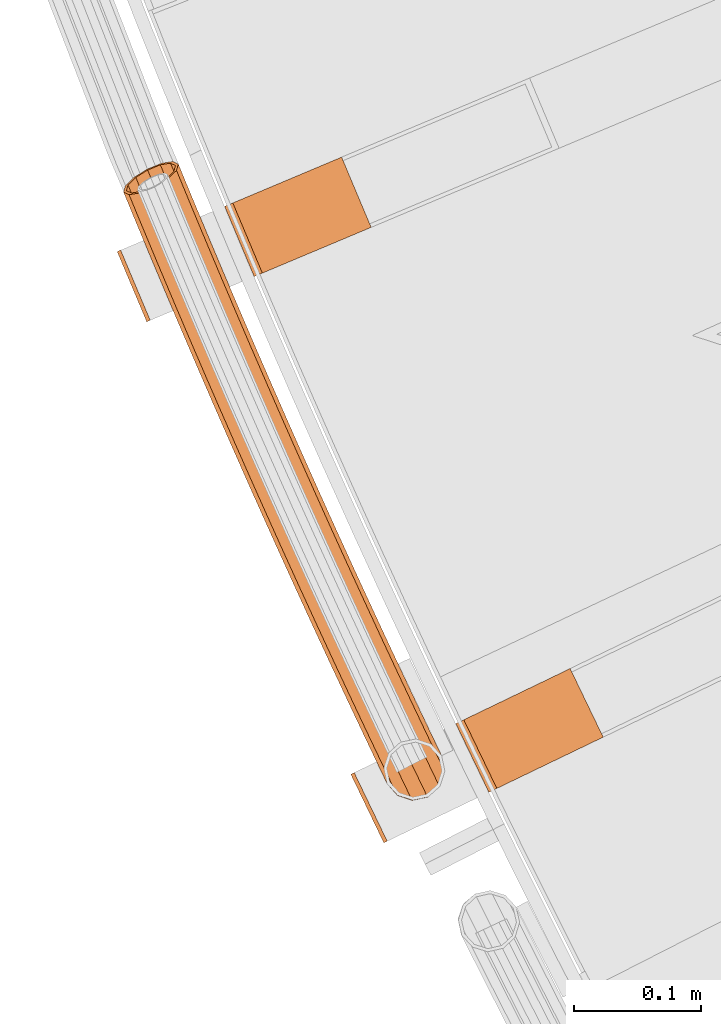
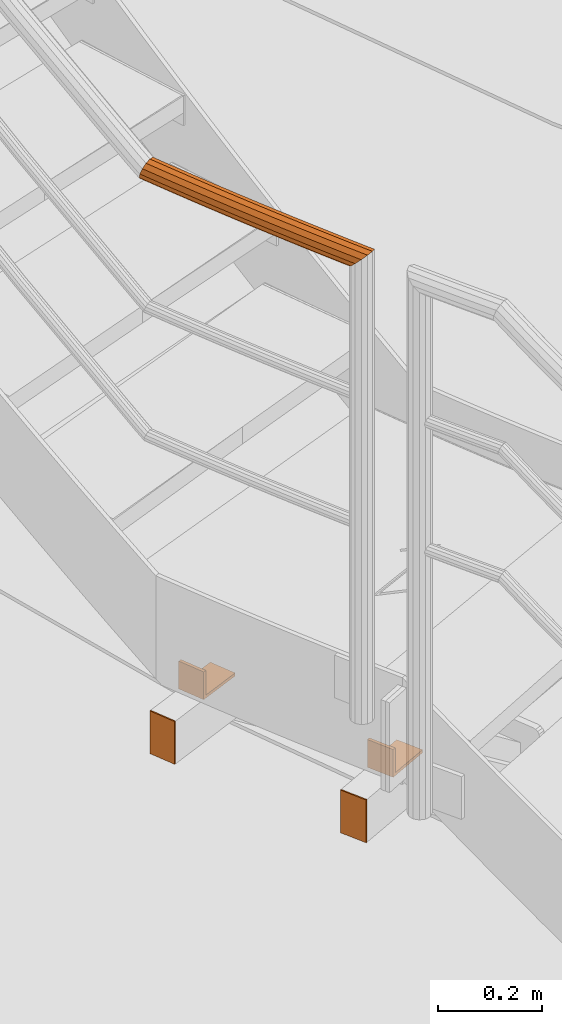
# One storey, part 47 of 126: 5 proxies.
"""IFC2X3 building model written with IfcOpenShell, lengths in millimetres."""

from ifc_helpers import new_model, si_unit, origin, origin_with_axes, place, context, project, spatial, faceted_brep, material, element, save


model = new_model("IFC2X3")

# Units and contexts
context_of_model_1 = context(None, 3, precision=0.1, world=origin())
context_of_model_2 = context(None, 3, precision=0.1, world=origin())
ifc_project = project(units=[si_unit("LENGTHUNIT", "METRE", prefix="MILLI"), si_unit("AREAUNIT", "SQUARE_METRE", prefix="CENTI"), si_unit("VOLUMEUNIT", "CUBIC_METRE", prefix="CENTI"), si_unit("MASSUNIT", "GRAM", prefix="KILO")], contexts=[context_of_model_1, context_of_model_2])

# Site, building, storey
site_placement = place(None, origin_with_axes())
site = spatial("IfcSite", under=ifc_project, at=site_placement, CompositionType="ELEMENT")
building_placement = place(site_placement, origin_with_axes())
building = spatial("IfcBuilding", under=site, at=building_placement, CompositionType="ELEMENT")
storey_placement = place(building_placement, origin_with_axes())
storey = spatial("IfcBuildingStorey", under=building, at=storey_placement, CompositionType="ELEMENT")

# Proxies
ifc_material = material(Name="S235JRG2")
proxy_1_placement = place(storey_placement, origin_with_axes())
element("IfcBuildingElementProxy", 1, at=proxy_1_placement, inside=storey, material=ifc_material, context=context_of_model_2, shape_type="Brep", body=[
    faceted_brep([(-35.5375, 4164.3292, 2521.2501), (-32.8349, 4165.6314, 2521.2501), (-6.7918, 4111.5781, 2521.2501), (-9.4944, 4110.276, 2521.2501), (-35.5375, 4164.3292, 2621.25), (-9.4944, 4110.276, 2621.25), (-6.7918, 4111.5781, 2621.25), (-32.8349, 4165.6314, 2621.25)], [[[0, 1, 2, 3]], [[4, 5, 6, 7]], [[0, 4, 7, 1]], [[1, 7, 6, 2]], [[2, 6, 5, 3]], [[3, 5, 4, 0]]]),
])
proxy_2_placement = place(storey_placement, origin_with_axes())
element("IfcBuildingElementProxy", 2, at=proxy_2_placement, inside=storey, material=ifc_material, context=context_of_model_2, shape_type="Brep", body=[
    faceted_brep([(73.2177, 4150.1271, 2686.25), (47.1746, 4204.1803, 2686.25), (47.1746, 4204.1803, 2621.25), (73.2177, 4150.1271, 2621.25), (79.5239, 4153.1655, 2686.25), (53.4808, 4207.2187, 2686.25), (79.5239, 4153.1655, 2628.25), (53.4808, 4207.2187, 2628.25), (163.3065, 4193.5323, 2628.25), (137.2634, 4247.5856, 2628.25), (163.3065, 4193.5323, 2621.25), (137.2634, 4247.5856, 2621.25)], [[[0, 1, 2, 3]], [[0, 4, 5, 1]], [[4, 6, 7, 5]], [[6, 8, 9, 7]], [[8, 10, 11, 9]], [[3, 2, 11, 10]], [[3, 10, 8, 6, 4, 0]], [[1, 5, 7, 9, 11, 2]]]),
])
proxy_3_placement = place(storey_placement, origin_with_axes())
element("IfcBuildingElementProxy", 3, at=proxy_3_placement, inside=storey, material=ifc_material, context=context_of_model_2, shape_type="Brep", body=[
    faceted_brep([(-219.5513, 4576.0422, 2521.2501), (-216.7862, 4577.206, 2521.2501), (-193.5112, 4521.9043, 2521.2501), (-196.2762, 4520.7406, 2521.2501), (-219.5513, 4576.0422, 2621.25), (-196.2762, 4520.7406, 2621.25), (-193.5112, 4521.9043, 2621.25), (-216.7862, 4577.206, 2621.25)], [[[0, 1, 2, 3]], [[4, 5, 6, 7]], [[0, 4, 7, 1]], [[1, 7, 6, 2]], [[2, 6, 5, 3]], [[3, 5, 4, 0]]]),
])
proxy_4_placement = place(storey_placement, origin_with_axes())
element("IfcBuildingElementProxy", 4, at=proxy_4_placement, inside=storey, material=ifc_material, context=context_of_model_2, shape_type="Brep", body=[
    faceted_brep([(-111.6539, 4556.356, 2686.25), (-134.9289, 4611.6576, 2686.25), (-134.9289, 4611.6576, 2621.25), (-111.6539, 4556.356, 2621.25), (-105.202, 4559.0714, 2686.25), (-128.4771, 4614.373, 2686.25), (-105.202, 4559.0714, 2628.25), (-128.4771, 4614.373, 2628.25), (-19.4845, 4595.1478, 2628.25), (-42.7595, 4650.4494, 2628.25), (-19.4845, 4595.1478, 2621.25), (-42.7595, 4650.4494, 2621.25)], [[[0, 1, 2, 3]], [[0, 4, 5, 1]], [[4, 6, 7, 5]], [[6, 8, 9, 7]], [[8, 10, 11, 9]], [[3, 2, 11, 10]], [[3, 10, 8, 6, 4, 0]], [[1, 5, 7, 9, 11, 2]]]),
])
proxy_5_placement = place(storey_placement, origin_with_axes())
element("IfcBuildingElementProxy", 5, at=proxy_5_placement, inside=storey, material=ifc_material, Name="HANDLAUF", context=context_of_model_2, shape_type="Brep", body=[
    faceted_brep([(32.0746, 4159.3173, 3868.0145), (34.3313, 4154.6595, 3868.0145), (36.6319, 4161.5155, 3862.9548), (21.1986, 4154.0714, 3871.25), (24.9858, 4146.2546, 3871.25), (10.3227, 4148.8254, 3868.0145), (12.8183, 4143.6745, 3868.0145), (5.0488, 4146.2816, 3862.1592), (11.4486, 4149.3685, 3865.8494), (12.9876, 4146.1919, 3865.8494), (8.1962, 4147.7997, 3862.2385), (21.1986, 4154.0714, 3868.75), (23.8956, 4148.5049, 3868.75), (30.9487, 4158.7743, 3865.8494), (32.2736, 4156.0398, 3865.8494), (33.6242, 4160.0647, 3862.879), (-13.9833, 4171.5476, 3847.1), (-11.0643, 4172.9431, 3835.025), (-9.3589, 4169.3917, 3835.025), (-7.0128, 4157.0315, 3847.1), (-7.6016, 4174.5984, 3831.187), (26.6743, 4190.9839, 3835.025), (27.9056, 4188.4199, 3835.025), (24.0399, 4189.7246, 3832.1051), (29.5934, 4192.3794, 3847.1), (36.0165, 4179.0034, 3847.1), (26.6743, 4190.9839, 3859.175), (38.3626, 4166.6432, 3859.175), (18.6992, 4187.1714, 3868.0145), (7.805, 4181.9635, 3871.25), (-3.0892, 4176.7556, 3868.0145), (1.0981, 4147.615, 3859.175), (-11.0643, 4172.9431, 3859.175), (-11.7278, 4172.6259, 3847.1), (-9.1109, 4173.8769, 3857.925), (2.4856, 4149.7271, 3857.925), (-4.7856, 4158.1688, 3847.1), (-1.9614, 4177.2947, 3865.8494), (7.805, 4181.9635, 3868.75), (17.5715, 4186.6323, 3865.8494), (24.721, 4190.0501, 3857.925), (35.8925, 4166.7855, 3857.925), (27.3379, 4191.3011, 3847.1), (33.7893, 4177.8661, 3847.1), (24.721, 4190.0501, 3836.275), (26.518, 4186.3078, 3836.275), (20.876, 4188.212, 3832.0133), (-9.1109, 4173.8769, 3836.275), (-6.8888, 4169.2494, 3836.275), (-4.5991, 4176.0337, 3831.2741), (-27.3157, 4199.5625, 3847.1), (-24.3918, 4200.9477, 3835.025), (-16.4034, 4204.7323, 3826.1855), (-5.2956, 4181.3918, 3826.1855), (-5.4911, 4209.9022, 3822.95), (4.0719, 4189.8079, 3822.95), (5.4212, 4215.0721, 3826.1855), (16.2211, 4192.3787, 3826.1855), (13.4095, 4218.8567, 3835.025), (16.3335, 4220.242, 3847.1), (13.4095, 4218.8567, 3859.175), (5.4212, 4215.0721, 3868.0145), (-5.4911, 4209.9022, 3871.25), (-16.4034, 4204.7323, 3868.0145), (-24.3918, 4200.9477, 3859.175), (-25.0565, 4200.6328, 3847.1), (-22.4352, 4201.8747, 3857.925), (-15.2738, 4205.2675, 3865.8494), (-5.4911, 4209.9022, 3868.75), (4.2915, 4214.5369, 3865.8494), (11.4529, 4217.9297, 3857.925), (14.0742, 4219.1716, 3847.1), (11.4529, 4217.9297, 3836.275), (16.0381, 4189.8543, 3828.3506), (4.2915, 4214.5369, 3828.3506), (-5.4911, 4209.9022, 3825.45), (5.1466, 4187.5496, 3825.45), (-15.2738, 4205.2675, 3828.3506), (-3.2511, 4180.0047, 3828.3506), (-22.4352, 4201.8747, 3836.275), (-40.5503, 4227.6237, 3847.1), (-37.6215, 4228.9987, 3835.025), (-29.62, 4232.7554, 3826.1855), (-18.6897, 4237.8872, 3822.95), (-7.7594, 4243.0189, 3826.1855), (0.2421, 4246.7756, 3835.025), (3.1709, 4248.1507, 3847.1), (0.2421, 4246.7756, 3859.175), (-7.7594, 4243.0189, 3868.0145), (-18.6897, 4237.8872, 3871.25), (-29.62, 4232.7554, 3868.0145), (-37.6215, 4228.9987, 3859.175), (-38.2873, 4228.6861, 3847.1), (-35.6617, 4229.9188, 3857.925), (-28.4885, 4233.2866, 3865.8494), (-18.6897, 4237.8872, 3868.75), (-8.8909, 4242.4877, 3865.8494), (-1.7177, 4245.8555, 3857.925), (0.9079, 4247.0882, 3847.1), (-1.7177, 4245.8555, 3836.275), (-8.8909, 4242.4877, 3828.3506), (-18.6897, 4237.8872, 3825.45), (-28.4885, 4233.2866, 3828.3506), (-35.6617, 4229.9188, 3836.275), (-53.6867, 4255.7309, 3847.1), (-50.7532, 4257.0957, 3835.025), (-42.7386, 4260.8244, 3826.1855), (-31.7905, 4265.918, 3822.95), (-20.8424, 4271.0116, 3826.1855), (-12.8278, 4274.7403, 3835.025), (-9.8942, 4276.1052, 3847.1), (-12.8278, 4274.7403, 3859.175), (-20.8424, 4271.0116, 3868.0145), (-31.7905, 4265.918, 3871.25), (-42.7386, 4260.8244, 3868.0145), (-50.7532, 4257.0957, 3859.175), (-51.4201, 4256.7854, 3847.1), (-48.7902, 4258.009, 3857.925), (-41.6053, 4261.3517, 3865.8494), (-31.7905, 4265.918, 3868.75), (-21.9757, 4270.4843, 3865.8494), (-14.7908, 4273.8271, 3857.925), (-12.1609, 4275.0506, 3847.1), (-14.7908, 4273.8271, 3836.275), (-21.9757, 4270.4843, 3828.3506), (-31.7905, 4265.918, 3825.45), (-41.6053, 4261.3517, 3828.3506), (-48.7902, 4258.009, 3836.275), (-66.725, 4283.8838, 3847.1), (-63.7868, 4285.2384, 3835.025), (-55.7592, 4288.9391, 3826.1855), (-44.7934, 4293.9944, 3822.95), (-33.8275, 4299.0498, 3826.1855), (-25.8, 4302.7505, 3835.025), (-22.8617, 4304.1051, 3847.1), (-25.8, 4302.7505, 3859.175), (-33.8275, 4299.0498, 3868.0145), (-44.7934, 4293.9944, 3871.25), (-55.7592, 4288.9391, 3868.0145), (-63.7868, 4285.2384, 3859.175), (-64.4547, 4284.9304, 3847.1), (-61.8206, 4286.1448, 3857.925), (-54.624, 4289.4624, 3865.8494), (-44.7934, 4293.9944, 3868.75), (-34.9627, 4298.5264, 3865.8494), (-27.7661, 4301.8441, 3857.925), (-25.132, 4303.0584, 3847.1), (-27.7661, 4301.8441, 3836.275), (-34.9627, 4298.5264, 3828.3506), (-44.7934, 4293.9944, 3825.45), (-54.624, 4289.4624, 3828.3506), (-61.8206, 4286.1448, 3836.275), (-79.665, 4312.082, 3847.1), (-76.722, 4313.4263, 3835.025), (-68.6816, 4317.0991, 3826.1855), (-57.6981, 4322.1161, 3822.95), (-46.7147, 4327.1331, 3826.1855), (-38.6743, 4330.8058, 3835.025), (-35.7313, 4332.1501, 3847.1), (-38.6743, 4330.8058, 3859.175), (-46.7147, 4327.1331, 3868.0145), (-57.6981, 4322.1161, 3871.25), (-68.6816, 4317.0991, 3868.0145), (-76.722, 4313.4263, 3859.175), (-77.391, 4313.1208, 3847.1), (-74.7526, 4314.3259, 3857.925), (-67.5446, 4317.6184, 3865.8494), (-57.6981, 4322.1161, 3868.75), (-47.8517, 4326.6137, 3865.8494), (-40.6436, 4329.9062, 3857.925), (-38.0053, 4331.1114, 3847.1), (-40.6436, 4329.9062, 3836.275), (-47.8517, 4326.6137, 3828.3506), (-57.6981, 4322.1161, 3825.45), (-67.5446, 4317.6184, 3828.3506), (-74.7526, 4314.3259, 3836.275), (-92.5064, 4340.3253, 3847.1), (-89.5587, 4341.6593, 3835.025), (-81.5056, 4345.3039, 3826.1855), (-70.5047, 4350.2826, 3822.95), (-59.5038, 4355.2612, 3826.1855), (-51.4506, 4358.9058, 3835.025), (-48.5029, 4360.2399, 3847.1), (-51.4506, 4358.9058, 3859.175), (-59.5038, 4355.2612, 3868.0145), (-70.5047, 4350.2826, 3871.25), (-81.5056, 4345.3039, 3868.0145), (-89.5587, 4341.6593, 3859.175), (-90.2288, 4341.3561, 3847.1), (-87.5863, 4342.552, 3857.925), (-80.3667, 4345.8193, 3865.8494), (-70.5047, 4350.2826, 3868.75), (-60.6426, 4354.7458, 3865.8494), (-53.4231, 4358.0132, 3857.925), (-50.7806, 4359.2091, 3847.1), (-53.4231, 4358.0132, 3836.275), (-60.6426, 4354.7458, 3828.3506), (-70.5047, 4350.2826, 3825.45), (-80.3667, 4345.8193, 3828.3506), (-87.5863, 4342.552, 3836.275), (-105.2492, 4368.6132, 3847.1), (-102.2969, 4369.9369, 3835.025), (-94.231, 4373.5534, 3826.1855), (-83.2128, 4378.4936, 3822.95), (-72.1946, 4383.4338, 3826.1855), (-64.1288, 4387.0503, 3835.025), (-61.1765, 4388.374, 3847.1), (-64.1288, 4387.0503, 3859.175), (-72.1946, 4383.4338, 3868.0145), (-83.2128, 4378.4936, 3871.25), (-94.231, 4373.5534, 3868.0145), (-102.2969, 4369.9369, 3859.175), (-102.968, 4369.636, 3847.1), (-100.3213, 4370.8227, 3857.925), (-93.0904, 4374.0648, 3865.8494), (-83.2128, 4378.4936, 3868.75), (-73.3352, 4382.9224, 3865.8494), (-66.1044, 4386.1645, 3857.925), (-63.4577, 4387.3512, 3847.1), (-66.1044, 4386.1645, 3836.275), (-73.3352, 4382.9224, 3828.3506), (-83.2128, 4378.4936, 3825.45), (-93.0904, 4374.0648, 3828.3506), (-100.3213, 4370.8227, 3836.275), (-117.8931, 4396.9454, 3847.1), (-114.9362, 4398.2588, 3835.025), (-106.8578, 4401.8471, 3826.1855), (-95.8224, 4406.7488, 3822.95), (-84.7871, 4411.6506, 3826.1855), (-76.7086, 4415.2389, 3835.025), (-73.7517, 4416.5523, 3847.1), (-76.7086, 4415.2389, 3859.175), (-84.7871, 4411.6506, 3868.0145), (-95.8224, 4406.7488, 3871.25), (-106.8578, 4401.8471, 3868.0145), (-114.9362, 4398.2588, 3859.175), (-115.6084, 4397.9602, 3847.1), (-112.9576, 4399.1377, 3857.925), (-105.7154, 4402.3545, 3865.8494), (-95.8224, 4406.7488, 3868.75), (-85.9294, 4411.1431, 3865.8494), (-78.6873, 4414.36, 3857.925), (-76.0365, 4415.5374, 3847.1), (-78.6873, 4414.36, 3836.275), (-85.9294, 4411.1431, 3828.3506), (-95.8224, 4406.7488, 3825.45), (-105.7154, 4402.3545, 3828.3506), (-112.9576, 4399.1377, 3836.275), (-130.4381, 4425.3216, 3847.1), (-127.4766, 4426.6246, 3835.025), (-119.3857, 4430.1847, 3826.1855), (-108.3333, 4435.0479, 3822.95), (-97.2809, 4439.9111, 3826.1855), (-89.19, 4443.4712, 3835.025), (-86.2285, 4444.7743, 3847.1), (-89.19, 4443.4712, 3859.175), (-97.2809, 4439.9111, 3868.0145), (-108.3333, 4435.0479, 3871.25), (-119.3857, 4430.1847, 3868.0145), (-127.4766, 4426.6246, 3859.175), (-128.1498, 4426.3284, 3847.1), (-125.4949, 4427.4966, 3857.925), (-118.2416, 4430.6882, 3865.8494), (-108.3333, 4435.0479, 3868.75), (-98.425, 4439.4076, 3865.8494), (-91.1717, 4442.5992, 3857.925), (-88.5168, 4443.7674, 3847.1), (-91.1717, 4442.5992, 3836.275), (-98.425, 4439.4076, 3828.3506), (-108.3333, 4435.0479, 3825.45), (-118.2416, 4430.6882, 3828.3506), (-125.4949, 4427.4966, 3836.275), (-142.884, 4453.7413, 3847.1), (-139.9179, 4455.0341, 3835.025), (-131.8146, 4458.5659, 3826.1855), (-120.7453, 4463.3905, 3822.95), (-109.676, 4468.215, 3826.1855), (-101.5727, 4471.7469, 3835.025), (-98.6067, 4473.0396, 3847.1), (-101.5727, 4471.7469, 3859.175), (-109.676, 4468.215, 3868.0145), (-120.7453, 4463.3905, 3871.25), (-131.8146, 4458.5659, 3868.0145), (-139.9179, 4455.0341, 3859.175), (-140.5922, 4454.7402, 3847.1), (-137.9332, 4455.8991, 3857.925), (-130.6688, 4459.0653, 3865.8494), (-120.7453, 4463.3905, 3868.75), (-110.8219, 4467.7156, 3865.8494), (-103.5575, 4470.8818, 3857.925), (-100.8985, 4472.0407, 3847.1), (-103.5575, 4470.8818, 3836.275), (-110.8219, 4467.7156, 3828.3506), (-120.7453, 4463.3905, 3825.45), (-130.6688, 4459.0653, 3828.3506), (-137.9332, 4455.8991, 3836.275), (-155.2305, 4482.2044, 3847.1), (-152.26, 4483.4868, 3835.025), (-144.1444, 4486.9903, 3826.1855), (-133.0584, 4491.7762, 3822.95), (-121.9723, 4496.5621, 3826.1855), (-113.8567, 4500.0656, 3835.025), (-110.8862, 4501.348, 3847.1), (-113.8567, 4500.0656, 3859.175), (-121.9723, 4496.5621, 3868.0145), (-133.0584, 4491.7762, 3871.25), (-144.1444, 4486.9903, 3868.0145), (-152.26, 4483.4868, 3859.175), (-152.9353, 4483.1953, 3847.1), (-150.2723, 4484.3449, 3857.925), (-142.9968, 4487.4857, 3865.8494), (-133.0584, 4491.7762, 3868.75), (-123.1199, 4496.0667, 3865.8494), (-115.8444, 4499.2075, 3857.925), (-113.1814, 4500.3571, 3847.1), (-115.8444, 4499.2075, 3836.275), (-123.1199, 4496.0667, 3828.3506), (-133.0584, 4491.7762, 3825.45), (-142.9968, 4487.4857, 3828.3506), (-150.2723, 4484.3449, 3836.275), (-167.4777, 4510.7104, 3847.1), (-164.5027, 4511.9824, 3835.025), (-156.3749, 4515.4576, 3826.1855), (-145.2722, 4520.2047, 3822.95), (-134.1695, 4524.9519, 3826.1855), (-126.0417, 4528.4271, 3835.025), (-123.0668, 4529.6991, 3847.1), (-126.0417, 4528.4271, 3859.175), (-134.1695, 4524.9519, 3868.0145), (-145.2722, 4520.2047, 3871.25), (-156.3749, 4515.4576, 3868.0145), (-164.5027, 4511.9824, 3859.175), (-165.179, 4511.6932, 3847.1), (-162.512, 4512.8336, 3857.925), (-155.2256, 4515.949, 3865.8494), (-145.2722, 4520.2047, 3868.75), (-135.3188, 4524.4605, 3865.8494), (-128.0325, 4527.5759, 3857.925), (-125.3655, 4528.7162, 3847.1), (-128.0325, 4527.5759, 3836.275), (-135.3188, 4524.4605, 3828.3506), (-145.2722, 4520.2047, 3825.45), (-155.2256, 4515.949, 3828.3506), (-162.512, 4512.8336, 3836.275), (-179.6252, 4539.2589, 3847.1), (-176.6458, 4540.5206, 3835.025), (-168.506, 4543.9673, 3826.1855), (-157.3868, 4548.6757, 3822.95), (-146.2675, 4553.3841, 3826.1855), (-138.1277, 4556.8309, 3835.025), (-135.1483, 4558.0925, 3847.1), (-138.1277, 4556.8309, 3859.175), (-146.2675, 4553.3841, 3868.0145), (-157.3868, 4548.6757, 3871.25), (-168.506, 4543.9673, 3868.0145), (-176.6458, 4540.5206, 3859.175), (-177.3231, 4540.2338, 3847.1), (-174.6521, 4541.3648, 3857.925), (-167.3549, 4544.4547, 3865.8494), (-157.3868, 4548.6757, 3868.75), (-147.4186, 4552.8967, 3865.8494), (-140.1214, 4555.9867, 3857.925), (-137.4504, 4557.1177, 3847.1), (-140.1214, 4555.9867, 3836.275), (-147.4186, 4552.8967, 3828.3506), (-157.3868, 4548.6757, 3825.45), (-167.3549, 4544.4547, 3828.3506), (-174.6521, 4541.3648, 3836.275), (-191.6731, 4567.8497, 3847.1), (-188.6893, 4569.1009, 3835.025), (-180.5375, 4572.5193, 3826.1855), (-169.4019, 4577.1888, 3822.95), (-158.2663, 4581.8584, 3826.1855), (-150.1144, 4585.2767, 3835.025), (-147.1307, 4586.5279, 3847.1), (-150.1144, 4585.2767, 3859.175), (-158.2663, 4581.8584, 3868.0145), (-169.4019, 4577.1888, 3871.25), (-180.5375, 4572.5193, 3868.0145), (-188.6893, 4569.1009, 3859.175), (-189.3675, 4568.8165, 3847.1), (-186.6927, 4569.9382, 3857.925), (-179.3847, 4573.0027, 3865.8494), (-169.4019, 4577.1888, 3868.75), (-159.419, 4581.375, 3865.8494), (-152.1111, 4584.4394, 3857.925), (-149.4362, 4585.5611, 3847.1), (-152.1111, 4584.4394, 3836.275), (-159.419, 4581.375, 3828.3506), (-169.4019, 4577.1888, 3825.45), (-179.3847, 4573.0027, 3828.3506), (-186.6927, 4569.9382, 3836.275), (-203.621, 4596.4824, 3847.1), (-200.6329, 4597.7232, 3835.025), (-192.4692, 4601.113, 3826.1855), (-181.3174, 4605.7437, 3822.95), (-170.1655, 4610.3743, 3826.1855), (-162.0018, 4613.7642, 3835.025), (-159.0137, 4615.005, 3847.1), (-162.0018, 4613.7642, 3859.175), (-170.1655, 4610.3743, 3868.0145), (-181.3174, 4605.7437, 3871.25), (-192.4692, 4601.113, 3868.0145), (-200.6329, 4597.7232, 3859.175), (-201.3121, 4597.4411, 3847.1), (-198.6333, 4598.5535, 3857.925), (-191.3147, 4601.5924, 3865.8494), (-181.3174, 4605.7437, 3868.75), (-171.32, 4609.895, 3865.8494), (-164.0014, 4612.9339, 3857.925), (-161.3226, 4614.0462, 3847.1), (-164.0014, 4612.9339, 3836.275), (-171.32, 4609.895, 3828.3506), (-181.3174, 4605.7437, 3825.45), (-191.3147, 4601.5924, 3828.3506), (-198.6333, 4598.5535, 3836.275), (-214.5412, 4622.9112, 3847.1), (-213.6946, 4625.8861, 3839.9402), (-212.4765, 4626.3869, 3835.025), (-204.301, 4629.7483, 3826.1855), (-193.1331, 4634.34, 3822.95), (-181.9652, 4638.9317, 3826.1855), (-173.7897, 4642.293, 3835.025), (-170.7973, 4643.5234, 3847.1), (-171.9226, 4643.0607, 3851.6409), (-172.8134, 4639.9302, 3859.175), (-179.6403, 4633.3051, 3868.0145), (-190.0371, 4626.8472, 3871.25), (-201.2181, 4622.2869, 3868.0145), (-210.1871, 4620.8463, 3859.175), (-212.3074, 4624.0518, 3847.1), (-208.4042, 4622.2006, 3857.925), (-200.3635, 4623.4921, 3865.8494), (-190.3401, 4627.5803, 3868.75), (-181.0195, 4633.3697, 3865.8494), (-174.8993, 4639.309, 3857.925), (-174.0847, 4642.1717, 3851.0353), (-173.1095, 4642.5727, 3847.1), (-175.7921, 4641.4697, 3836.275), (-183.1213, 4638.4563, 3828.3506), (-193.1331, 4634.34, 3825.45), (-203.1449, 4630.2236, 3828.3506), (-210.4741, 4627.2102, 3836.275), (-211.5325, 4626.7751, 3840.5458), (-213.1082, 4627.9311, 3835.025), (-206.2703, 4634.5619, 3826.1855), (-195.8672, 4641.023, 3822.95), (-184.6864, 4645.5831, 3826.1855), (-175.7238, 4647.0205, 3835.025), (-171.3809, 4644.9499, 3847.1), (-173.6152, 4643.809, 3847.1), (-177.5086, 4645.6652, 3836.275), (-185.5434, 4644.3767, 3828.3506), (-195.5667, 4640.2886, 3825.45), (-204.8929, 4634.4963, 3828.3506), (-211.023, 4628.5519, 3836.275)], [[[0, 1, 2]], [[0, 3, 4, 1]], [[3, 5, 6, 4]], [[5, 7, 6]], [[8, 9, 10]], [[8, 11, 12, 9]], [[11, 13, 14, 12]], [[13, 15, 14]], [[16, 17, 18, 19]], [[17, 20, 18]], [[21, 22, 23]], [[21, 24, 25, 22]], [[24, 26, 27, 25]], [[0, 2, 27, 26, 28]], [[0, 28, 29, 3]], [[3, 29, 30, 5]], [[31, 7, 5, 30, 32]], [[16, 19, 31, 32]], [[33, 34, 35, 36]], [[35, 34, 37, 8, 10]], [[8, 37, 38, 11]], [[11, 38, 39, 13]], [[13, 39, 40, 41, 15]], [[40, 42, 43, 41]], [[42, 44, 45, 43]], [[44, 46, 45]], [[47, 48, 49]], [[33, 36, 48, 47]], [[16, 50, 51, 17]], [[17, 51, 52, 53, 20]], [[52, 54, 55, 53]], [[54, 56, 57, 55]], [[57, 56, 58, 21, 23]], [[21, 58, 59, 24]], [[24, 59, 60, 26]], [[26, 60, 61, 28]], [[28, 61, 62, 29]], [[29, 62, 63, 30]], [[30, 63, 64, 32]], [[32, 64, 50, 16]], [[33, 65, 66, 34]], [[34, 66, 67, 37]], [[37, 67, 68, 38]], [[38, 68, 69, 39]], [[39, 69, 70, 40]], [[40, 70, 71, 42]], [[42, 71, 72, 44]], [[73, 46, 44, 72, 74]], [[74, 75, 76, 73]], [[75, 77, 78, 76]], [[47, 49, 78, 77, 79]], [[47, 79, 65, 33]], [[50, 80, 81, 51]], [[51, 81, 82, 52]], [[52, 82, 83, 54]], [[54, 83, 84, 56]], [[56, 84, 85, 58]], [[58, 85, 86, 59]], [[59, 86, 87, 60]], [[60, 87, 88, 61]], [[61, 88, 89, 62]], [[62, 89, 90, 63]], [[63, 90, 91, 64]], [[64, 91, 80, 50]], [[65, 92, 93, 66]], [[66, 93, 94, 67]], [[67, 94, 95, 68]], [[68, 95, 96, 69]], [[69, 96, 97, 70]], [[70, 97, 98, 71]], [[71, 98, 99, 72]], [[72, 99, 100, 74]], [[74, 100, 101, 75]], [[75, 101, 102, 77]], [[77, 102, 103, 79]], [[79, 103, 92, 65]], [[80, 104, 105, 81]], [[81, 105, 106, 82]], [[82, 106, 107, 83]], [[83, 107, 108, 84]], [[84, 108, 109, 85]], [[85, 109, 110, 86]], [[86, 110, 111, 87]], [[87, 111, 112, 88]], [[88, 112, 113, 89]], [[89, 113, 114, 90]], [[90, 114, 115, 91]], [[91, 115, 104, 80]], [[92, 116, 117, 93]], [[93, 117, 118, 94]], [[94, 118, 119, 95]], [[95, 119, 120, 96]], [[96, 120, 121, 97]], [[97, 121, 122, 98]], [[98, 122, 123, 99]], [[99, 123, 124, 100]], [[100, 124, 125, 101]], [[101, 125, 126, 102]], [[102, 126, 127, 103]], [[103, 127, 116, 92]], [[104, 128, 129, 105]], [[105, 129, 130, 106]], [[106, 130, 131, 107]], [[107, 131, 132, 108]], [[108, 132, 133, 109]], [[109, 133, 134, 110]], [[110, 134, 135, 111]], [[111, 135, 136, 112]], [[112, 136, 137, 113]], [[113, 137, 138, 114]], [[114, 138, 139, 115]], [[115, 139, 128, 104]], [[116, 140, 141, 117]], [[117, 141, 142, 118]], [[118, 142, 143, 119]], [[119, 143, 144, 120]], [[120, 144, 145, 121]], [[121, 145, 146, 122]], [[122, 146, 147, 123]], [[123, 147, 148, 124]], [[124, 148, 149, 125]], [[125, 149, 150, 126]], [[126, 150, 151, 127]], [[127, 151, 140, 116]], [[128, 152, 153, 129]], [[129, 153, 154, 130]], [[130, 154, 155, 131]], [[131, 155, 156, 132]], [[132, 156, 157, 133]], [[133, 157, 158, 134]], [[134, 158, 159, 135]], [[135, 159, 160, 136]], [[136, 160, 161, 137]], [[137, 161, 162, 138]], [[138, 162, 163, 139]], [[139, 163, 152, 128]], [[140, 164, 165, 141]], [[141, 165, 166, 142]], [[142, 166, 167, 143]], [[143, 167, 168, 144]], [[144, 168, 169, 145]], [[145, 169, 170, 146]], [[146, 170, 171, 147]], [[147, 171, 172, 148]], [[148, 172, 173, 149]], [[149, 173, 174, 150]], [[150, 174, 175, 151]], [[151, 175, 164, 140]], [[152, 176, 177, 153]], [[153, 177, 178, 154]], [[154, 178, 179, 155]], [[155, 179, 180, 156]], [[156, 180, 181, 157]], [[157, 181, 182, 158]], [[158, 182, 183, 159]], [[159, 183, 184, 160]], [[160, 184, 185, 161]], [[161, 185, 186, 162]], [[162, 186, 187, 163]], [[163, 187, 176, 152]], [[164, 188, 189, 165]], [[165, 189, 190, 166]], [[166, 190, 191, 167]], [[167, 191, 192, 168]], [[168, 192, 193, 169]], [[169, 193, 194, 170]], [[170, 194, 195, 171]], [[171, 195, 196, 172]], [[172, 196, 197, 173]], [[173, 197, 198, 174]], [[174, 198, 199, 175]], [[175, 199, 188, 164]], [[176, 200, 201, 177]], [[177, 201, 202, 178]], [[178, 202, 203, 179]], [[179, 203, 204, 180]], [[180, 204, 205, 181]], [[181, 205, 206, 182]], [[182, 206, 207, 183]], [[183, 207, 208, 184]], [[184, 208, 209, 185]], [[185, 209, 210, 186]], [[186, 210, 211, 187]], [[187, 211, 200, 176]], [[188, 212, 213, 189]], [[189, 213, 214, 190]], [[190, 214, 215, 191]], [[191, 215, 216, 192]], [[192, 216, 217, 193]], [[193, 217, 218, 194]], [[194, 218, 219, 195]], [[195, 219, 220, 196]], [[196, 220, 221, 197]], [[197, 221, 222, 198]], [[198, 222, 223, 199]], [[199, 223, 212, 188]], [[200, 224, 225, 201]], [[201, 225, 226, 202]], [[202, 226, 227, 203]], [[203, 227, 228, 204]], [[204, 228, 229, 205]], [[205, 229, 230, 206]], [[206, 230, 231, 207]], [[207, 231, 232, 208]], [[208, 232, 233, 209]], [[209, 233, 234, 210]], [[210, 234, 235, 211]], [[211, 235, 224, 200]], [[212, 236, 237, 213]], [[213, 237, 238, 214]], [[214, 238, 239, 215]], [[215, 239, 240, 216]], [[216, 240, 241, 217]], [[217, 241, 242, 218]], [[218, 242, 243, 219]], [[219, 243, 244, 220]], [[220, 244, 245, 221]], [[221, 245, 246, 222]], [[222, 246, 247, 223]], [[223, 247, 236, 212]], [[224, 248, 249, 225]], [[225, 249, 250, 226]], [[226, 250, 251, 227]], [[227, 251, 252, 228]], [[228, 252, 253, 229]], [[229, 253, 254, 230]], [[230, 254, 255, 231]], [[231, 255, 256, 232]], [[232, 256, 257, 233]], [[233, 257, 258, 234]], [[234, 258, 259, 235]], [[235, 259, 248, 224]], [[236, 260, 261, 237]], [[237, 261, 262, 238]], [[238, 262, 263, 239]], [[239, 263, 264, 240]], [[240, 264, 265, 241]], [[241, 265, 266, 242]], [[242, 266, 267, 243]], [[243, 267, 268, 244]], [[244, 268, 269, 245]], [[245, 269, 270, 246]], [[246, 270, 271, 247]], [[247, 271, 260, 236]], [[248, 272, 273, 249]], [[249, 273, 274, 250]], [[250, 274, 275, 251]], [[251, 275, 276, 252]], [[252, 276, 277, 253]], [[253, 277, 278, 254]], [[254, 278, 279, 255]], [[255, 279, 280, 256]], [[256, 280, 281, 257]], [[257, 281, 282, 258]], [[258, 282, 283, 259]], [[259, 283, 272, 248]], [[260, 284, 285, 261]], [[261, 285, 286, 262]], [[262, 286, 287, 263]], [[263, 287, 288, 264]], [[264, 288, 289, 265]], [[265, 289, 290, 266]], [[266, 290, 291, 267]], [[267, 291, 292, 268]], [[268, 292, 293, 269]], [[269, 293, 294, 270]], [[270, 294, 295, 271]], [[271, 295, 284, 260]], [[272, 296, 297, 273]], [[273, 297, 298, 274]], [[274, 298, 299, 275]], [[275, 299, 300, 276]], [[276, 300, 301, 277]], [[277, 301, 302, 278]], [[278, 302, 303, 279]], [[279, 303, 304, 280]], [[280, 304, 305, 281]], [[281, 305, 306, 282]], [[282, 306, 307, 283]], [[283, 307, 296, 272]], [[284, 308, 309, 285]], [[285, 309, 310, 286]], [[286, 310, 311, 287]], [[287, 311, 312, 288]], [[288, 312, 313, 289]], [[289, 313, 314, 290]], [[290, 314, 315, 291]], [[291, 315, 316, 292]], [[292, 316, 317, 293]], [[293, 317, 318, 294]], [[294, 318, 319, 295]], [[295, 319, 308, 284]], [[296, 320, 321, 297]], [[297, 321, 322, 298]], [[298, 322, 323, 299]], [[299, 323, 324, 300]], [[300, 324, 325, 301]], [[301, 325, 326, 302]], [[302, 326, 327, 303]], [[303, 327, 328, 304]], [[304, 328, 329, 305]], [[305, 329, 330, 306]], [[306, 330, 331, 307]], [[307, 331, 320, 296]], [[308, 332, 333, 309]], [[309, 333, 334, 310]], [[310, 334, 335, 311]], [[311, 335, 336, 312]], [[312, 336, 337, 313]], [[313, 337, 338, 314]], [[314, 338, 339, 315]], [[315, 339, 340, 316]], [[316, 340, 341, 317]], [[317, 341, 342, 318]], [[318, 342, 343, 319]], [[319, 343, 332, 308]], [[320, 344, 345, 321]], [[321, 345, 346, 322]], [[322, 346, 347, 323]], [[323, 347, 348, 324]], [[324, 348, 349, 325]], [[325, 349, 350, 326]], [[326, 350, 351, 327]], [[327, 351, 352, 328]], [[328, 352, 353, 329]], [[329, 353, 354, 330]], [[330, 354, 355, 331]], [[331, 355, 344, 320]], [[332, 356, 357, 333]], [[333, 357, 358, 334]], [[334, 358, 359, 335]], [[335, 359, 360, 336]], [[336, 360, 361, 337]], [[337, 361, 362, 338]], [[338, 362, 363, 339]], [[339, 363, 364, 340]], [[340, 364, 365, 341]], [[341, 365, 366, 342]], [[342, 366, 367, 343]], [[343, 367, 356, 332]], [[344, 368, 369, 345]], [[345, 369, 370, 346]], [[346, 370, 371, 347]], [[347, 371, 372, 348]], [[348, 372, 373, 349]], [[349, 373, 374, 350]], [[350, 374, 375, 351]], [[351, 375, 376, 352]], [[352, 376, 377, 353]], [[353, 377, 378, 354]], [[354, 378, 379, 355]], [[355, 379, 368, 344]], [[356, 380, 381, 357]], [[357, 381, 382, 358]], [[358, 382, 383, 359]], [[359, 383, 384, 360]], [[360, 384, 385, 361]], [[361, 385, 386, 362]], [[362, 386, 387, 363]], [[363, 387, 388, 364]], [[364, 388, 389, 365]], [[365, 389, 390, 366]], [[366, 390, 391, 367]], [[367, 391, 380, 356]], [[368, 392, 393, 369]], [[369, 393, 394, 370]], [[370, 394, 395, 371]], [[371, 395, 396, 372]], [[372, 396, 397, 373]], [[373, 397, 398, 374]], [[374, 398, 399, 375]], [[375, 399, 400, 376]], [[376, 400, 401, 377]], [[377, 401, 402, 378]], [[378, 402, 403, 379]], [[379, 403, 392, 368]], [[380, 404, 405, 381]], [[381, 405, 406, 382]], [[382, 406, 407, 383]], [[383, 407, 408, 384]], [[384, 408, 409, 385]], [[385, 409, 410, 386]], [[386, 410, 411, 387]], [[387, 411, 412, 388]], [[388, 412, 413, 389]], [[389, 413, 414, 390]], [[390, 414, 415, 391]], [[391, 415, 404, 380]], [[392, 416, 417, 418, 393]], [[393, 418, 419, 394]], [[394, 419, 420, 395]], [[395, 420, 421, 396]], [[396, 421, 422, 397]], [[397, 422, 423, 398]], [[399, 398, 423, 424, 425]], [[399, 425, 426, 400]], [[400, 426, 427, 401]], [[401, 427, 428, 402]], [[402, 428, 429, 403]], [[392, 403, 429, 416]], [[404, 430, 431, 405]], [[405, 431, 432, 406]], [[406, 432, 433, 407]], [[407, 433, 434, 408]], [[408, 434, 435, 409]], [[409, 435, 436, 437, 410]], [[410, 437, 438, 411]], [[411, 438, 439, 412]], [[412, 439, 440, 413]], [[413, 440, 441, 414]], [[414, 441, 442, 415]], [[404, 415, 442, 443, 430]], [[417, 444, 418]], [[418, 444, 445, 419]], [[419, 445, 446, 420]], [[420, 446, 447, 421]], [[421, 447, 448, 422]], [[422, 448, 449, 423]], [[423, 449, 424]], [[436, 450, 437]], [[437, 450, 451, 438]], [[438, 451, 452, 439]], [[439, 452, 453, 440]], [[440, 453, 454, 441]], [[441, 454, 455, 442]], [[442, 455, 443]], [[19, 18, 20, 53, 55, 57, 23, 22, 25, 27, 2, 1, 4, 6, 7, 31], [9, 12, 14, 15, 41, 43, 45, 46, 73, 76, 78, 49, 48, 36, 35, 10]], [[416, 429, 428, 427, 426, 425, 424, 449, 448, 447, 446, 445, 444, 417], [430, 443, 455, 454, 453, 452, 451, 450, 436, 435, 434, 433, 432, 431]]]),
])

save(model, "model.ifc")
